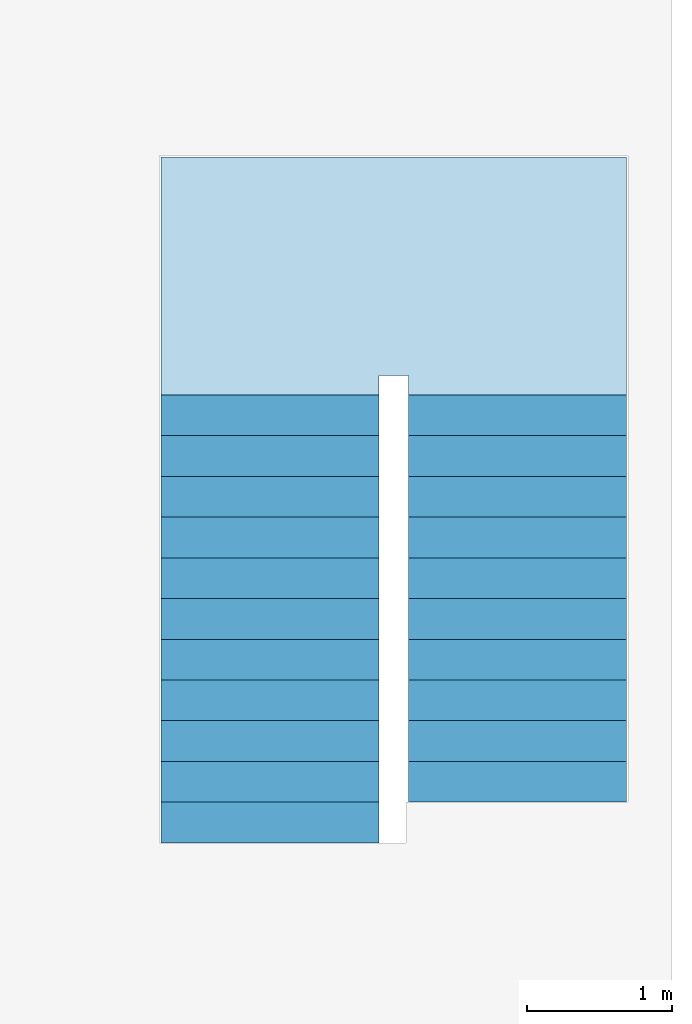
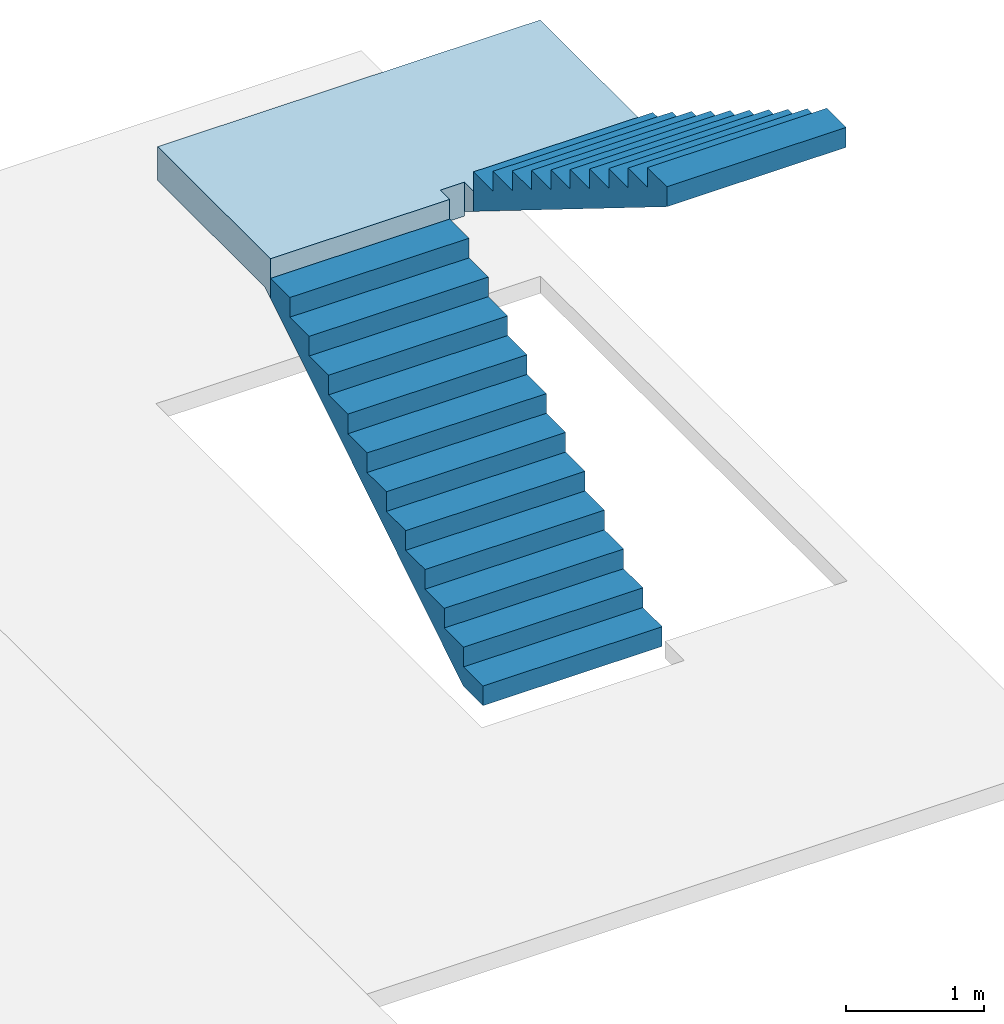
# One storey, part 2 of 2: 2 stair flights, 1 slab, 1 element without a shape of its own.
"""IFC2X3 building model written with IfcOpenShell, lengths in millimetres."""

from ifc_helpers import new_model, entity, si_unit, converted_unit, derived_unit, direction, frame, origin, place, context, subcontext, project, spatial, faceted_brep, material, element, aggregate, save


model = new_model("IFC2X3")

# Units and contexts
model_context = context("Model", 3, precision=0.01, world=origin(), true_north=direction((6.12303176911189e-17, 1.0)))
body_context = subcontext(model_context, "Body", "Model", "MODEL_VIEW")
ifc_project = project(units=[si_unit("LENGTHUNIT", "METRE", prefix="MILLI"), si_unit("AREAUNIT", "SQUARE_METRE"), si_unit("VOLUMEUNIT", "CUBIC_METRE"), converted_unit("PLANEANGLEUNIT", "DEGREE", entity("IfcRatioMeasure", 0.0174532925199433), si_unit("PLANEANGLEUNIT", "RADIAN"), dimensions=[0, 0, 0, 0, 0, 0, 0]), si_unit("MASSUNIT", "GRAM", prefix="KILO"), derived_unit("MASSDENSITYUNIT", [(si_unit("MASSUNIT", "GRAM", prefix="KILO"), 1), (si_unit("LENGTHUNIT", "METRE"), -3)]), si_unit("TIMEUNIT", "SECOND"), si_unit("FREQUENCYUNIT", "HERTZ"), si_unit("THERMODYNAMICTEMPERATUREUNIT", "DEGREE_CELSIUS"), derived_unit("THERMALTRANSMITTANCEUNIT", [(si_unit("MASSUNIT", "GRAM", prefix="KILO"), 1), (si_unit("THERMODYNAMICTEMPERATUREUNIT", "KELVIN"), -1), (si_unit("TIMEUNIT", "SECOND"), -3)]), derived_unit("VOLUMETRICFLOWRATEUNIT", [(si_unit("LENGTHUNIT", "METRE"), 3), (si_unit("TIMEUNIT", "SECOND"), -1)]), si_unit("ELECTRICCURRENTUNIT", "AMPERE"), si_unit("ELECTRICVOLTAGEUNIT", "VOLT"), si_unit("POWERUNIT", "WATT"), si_unit("FORCEUNIT", "NEWTON", prefix="KILO"), si_unit("ILLUMINANCEUNIT", "LUX"), si_unit("LUMINOUSFLUXUNIT", "LUMEN"), si_unit("LUMINOUSINTENSITYUNIT", "CANDELA"), derived_unit("USERDEFINED", [(si_unit("MASSUNIT", "GRAM", prefix="KILO"), -1), (si_unit("LENGTHUNIT", "METRE"), -2), (si_unit("TIMEUNIT", "SECOND"), 3), (si_unit("LUMINOUSFLUXUNIT", "LUMEN"), 1)]), derived_unit("LINEARVELOCITYUNIT", [(si_unit("LENGTHUNIT", "METRE"), 1), (si_unit("TIMEUNIT", "SECOND"), -1)]), si_unit("PRESSUREUNIT", "PASCAL"), derived_unit("USERDEFINED", [(si_unit("LENGTHUNIT", "METRE"), -2), (si_unit("MASSUNIT", "GRAM", prefix="KILO"), 1), (si_unit("TIMEUNIT", "SECOND"), -2)])], contexts=[model_context])

# Site, building, storey
site_placement = place(None, origin())
site = spatial("IfcSite", under=ifc_project, at=site_placement, CompositionType="ELEMENT")
building_placement = place(site_placement, origin())
building = spatial("IfcBuilding", under=site, at=building_placement, CompositionType="ELEMENT")
storey_placement = place(building_placement, frame((0.0, 0.0, 4000.0)))
storey = spatial("IfcBuildingStorey", under=building, at=storey_placement, Name="01 Level", CompositionType="ELEMENT", Elevation=4000.0)

# Stair, slab, stair flights
stair_placement = place(storey_placement, origin())
stair = element("IfcStair", 1, at=stair_placement, inside=storey, Name="Cast-In-Place Stair:Stair", ObjectType="Cast-In-Place Stair:Monolithic Stair", ShapeType="NOTDEFINED")
ifc_material = material(Name="Concrete, Cast In Situ")
slab_placement = place(stair_placement, frame((31263.4900708518, -68480.8241905963, 0.0)))
slab = element("IfcSlab", 2, at=slab_placement, material=ifc_material, Name="Cast-In-Place Stair:Stair:388632 Landing 1", ObjectType="Monolithic Landing:300mm Thickness", PredefinedType="LANDING", context=body_context, shape_type="Brep", body=[
    faceted_brep([(0.0, 0.0, 2086.95652173913), (1500.0, 0.0, 2086.95652173913), (1500.0, 81.2925429905189, 2086.95652173913), (1500.0, 135.0, 2086.95652173913), (1700.0, 135.0, 2086.95652173913), (1700.0, 0.0, 2086.95652173913), (3200.0, 0.0, 2086.95652173913), (3200.0, 198.707457009539, 2086.95652173913), (3200.0, 1635.0, 2086.95652173913), (0.0, 1635.0, 2086.95652173913), (0.0, 81.2925429905189, 2086.95652173913), (0.0, 0.0, 1913.04347826087), (0.0, 0.0, 1736.46425901212), (1500.0, 0.0, 1736.46425901212), (1500.0, 0.0, 1913.04347826087), (1500.0, 81.2925429905189, 1786.95652173913), (1500.0, 135.0, 1786.95652173913), (1700.0, 135.0, 1786.95652173913), (1700.0, 135.0, 1826.52637081337), (3200.0, 0.0, 1910.37730249039), (3200.0, 198.70745700953, 1786.95652173913), (3200.0, 1635.0, 1786.95652173913), (0.0, 1635.0, 1786.95652173913), (0.0, 81.2925429905189, 1786.95652173913), (1700.0, 198.70745700953, 1786.95652173913), (1700.0, 0.0, 1910.37730249039)], [[[0, 1, 2, 3, 4, 5, 6, 7, 8, 9, 10]], [[1, 0, 11, 12, 13, 14]], [[1, 14, 13, 15, 16, 3, 2]], [[4, 3, 16, 17, 18]], [[6, 19, 20, 21, 8, 7]], [[9, 8, 21, 22]], [[12, 11, 0, 10, 9, 22, 23]], [[24, 17, 16, 15, 23, 22, 21, 20]], [[17, 24, 18]], [[23, 15, 13, 12]], [[24, 20, 19, 25, 18]], [[5, 4, 18, 25]], [[6, 5, 25, 19]]]),
])
stair_flight_1_placement = place(stair_placement, frame((31263.4900708518, -71560.8241905963, 0.0)))
stair_flight_1 = element("IfcStairFlight", 3, at=stair_flight_1_placement, material=ifc_material, Name="Cast-In-Place Stair:Stair:388632 Run 1", ObjectType="Monolithic Run:150mm Depth", NumberOfRiser=12, NumberOfTreads=11, RiserHeight=0.57058085130663, TreadLength=0.918635170603675, context=body_context, shape_type="Brep", body=[
    faceted_brep([(0.0, 280.0, 173.913043478261), (0.0, 0.0, 173.913043478261), (1500.0, 0.0, 173.913043478261), (1500.0, 280.0, 173.913043478261), (0.0, 280.0, 0.0), (0.0, 0.0, 0.0), (1500.0, 0.0, 0.0), (1500.0, 280.0, 0.0), (0.0, 560.0, 347.826086956522), (0.0, 280.0, 347.826086956522), (1500.0, 280.0, 347.826086956522), (1500.0, 560.0, 347.826086956522), (0.0, 560.0, 171.246867707768), (0.0, 284.29254299049, 0.0), (1500.0, 284.29254299049, 0.0), (1500.0, 560.0, 171.246867707772), (0.0, 840.0, 521.739130434783), (0.0, 560.0, 521.739130434783), (1500.0, 560.0, 521.739130434783), (1500.0, 840.0, 521.739130434783), (0.0, 840.0, 345.159911186038), (1500.0, 840.0, 345.159911186036), (0.0, 1120.0, 695.652173913044), (0.0, 840.0, 695.652173913044), (1500.0, 840.0, 695.652173913044), (1500.0, 1120.0, 695.652173913044), (0.0, 1120.0, 519.07295466429), (1500.0, 1120.0, 519.072954664289), (0.0, 1400.0, 869.565217391304), (0.0, 1120.0, 869.565217391304), (1500.0, 1120.0, 869.565217391304), (1500.0, 1400.0, 869.565217391304), (0.0, 1400.0, 692.985998142542), (1500.0, 1400.0, 692.985998142554), (0.0, 1680.0, 1043.47826086956), (0.0, 1400.0, 1043.47826086956), (1500.0, 1400.0, 1043.47826086956), (1500.0, 1680.0, 1043.47826086956), (0.0, 1680.0, 866.899041620812), (1500.0, 1680.0, 866.899041620812), (0.0, 1960.0, 1217.39130434783), (0.0, 1680.0, 1217.39130434783), (1500.0, 1680.0, 1217.39130434783), (1500.0, 1960.0, 1217.39130434783), (0.0, 1960.0, 1040.81208509906), (1500.0, 1960.0, 1040.81208509907), (0.0, 2240.0, 1391.30434782609), (0.0, 1960.0, 1391.30434782609), (1500.0, 1960.0, 1391.30434782609), (1500.0, 2240.0, 1391.30434782609), (0.0, 2240.0, 1214.72512857734), (1500.0, 2240.0, 1214.72512857734), (0.0, 2520.0, 1565.21739130435), (0.0, 2240.0, 1565.21739130435), (1500.0, 2240.0, 1565.21739130435), (1500.0, 2520.0, 1565.21739130435), (0.0, 2520.0, 1388.63817205559), (1500.0, 2520.0, 1388.63817205559), (0.0, 2800.0, 1739.13043478261), (0.0, 2520.0, 1739.13043478261), (1500.0, 2520.0, 1739.13043478261), (1500.0, 2800.0, 1739.13043478261), (0.0, 2800.0, 1562.55121553385), (1500.0, 2800.0, 1562.55121553386), (0.0, 3080.0, 1913.04347826087), (0.0, 2800.0, 1913.04347826087), (1500.0, 2800.0, 1913.04347826087), (1500.0, 3080.0, 1913.04347826087), (0.0, 3080.0, 1736.46425901212), (1500.0, 3080.0, 1736.46425901212)], [[[0, 1, 2, 3]], [[1, 0, 4, 5]], [[2, 1, 5, 6]], [[3, 2, 6, 7]], [[8, 9, 10, 11]], [[4, 0, 9, 8, 12, 13]], [[0, 3, 10, 9]], [[3, 7, 14, 15, 11, 10]], [[16, 17, 18, 19]], [[17, 16, 20, 12, 8]], [[8, 11, 18, 17]], [[19, 18, 11, 15, 21]], [[22, 23, 24, 25]], [[23, 22, 26, 20, 16]], [[16, 19, 24, 23]], [[25, 24, 19, 21, 27]], [[28, 29, 30, 31]], [[29, 28, 32, 26, 22]], [[22, 25, 30, 29]], [[31, 30, 25, 27, 33]], [[34, 35, 36, 37]], [[35, 34, 38, 32, 28]], [[28, 31, 36, 35]], [[37, 36, 31, 33, 39]], [[40, 41, 42, 43]], [[41, 40, 44, 38, 34]], [[34, 37, 42, 41]], [[43, 42, 37, 39, 45]], [[46, 47, 48, 49]], [[47, 46, 50, 44, 40]], [[40, 43, 48, 47]], [[49, 48, 43, 45, 51]], [[52, 53, 54, 55]], [[53, 52, 56, 50, 46]], [[46, 49, 54, 53]], [[55, 54, 49, 51, 57]], [[58, 59, 60, 61]], [[59, 58, 62, 56, 52]], [[52, 55, 60, 59]], [[61, 60, 55, 57, 63]], [[64, 65, 66, 67]], [[65, 64, 68, 62, 58]], [[58, 61, 66, 65]], [[67, 66, 61, 63, 69]], [[64, 67, 69, 68]], [[5, 4, 13, 14, 7, 6]], [[14, 13, 12, 20, 26, 32, 38, 44, 50, 56, 62, 68, 69, 63, 57, 51, 45, 39, 33, 27, 21, 15]]]),
])
stair_flight_2_placement = place(stair_placement, frame((32963.4900708518, -71280.8241905964, 0.0)))
stair_flight_2 = element("IfcStairFlight", 4, at=stair_flight_2_placement, material=ifc_material, Name="Cast-In-Place Stair:Stair:388632 Run 2", ObjectType="Monolithic Run:150mm Depth", NumberOfRiser=11, NumberOfTreads=10, RiserHeight=0.57058085130663, TreadLength=0.918635170603675, context=body_context, shape_type="Brep", body=[
    faceted_brep([(1500.0, 2520.0, 2260.86956521739), (1500.0, 2800.0, 2260.86956521739), (0.0, 2800.0, 2260.86956521739), (0.0, 2520.0, 2260.86956521739), (1500.0, 2520.0, 2084.29034596864), (1500.0, 2800.0, 1910.37730249038), (1500.0, 2800.0, 2086.95652173913), (0.0, 2800.0, 1910.37730249038), (0.0, 2800.0, 2086.95652173913), (0.0, 2520.0, 2084.29034596864), (1500.0, 2240.0, 2434.78260869565), (1500.0, 2520.0, 2434.78260869565), (0.0, 2520.0, 2434.78260869565), (0.0, 2240.0, 2434.78260869565), (1500.0, 2240.0, 2258.20338944691), (0.0, 2240.0, 2258.2033894469), (1500.0, 1960.0, 2608.69565217391), (1500.0, 2240.0, 2608.69565217391), (0.0, 2240.0, 2608.69565217391), (0.0, 1960.0, 2608.69565217391), (1500.0, 1960.0, 2432.11643292516), (0.0, 1960.0, 2432.11643292516), (1500.0, 1680.0, 2782.60869565217), (1500.0, 1960.0, 2782.60869565217), (0.0, 1960.0, 2782.60869565217), (0.0, 1680.0, 2782.60869565217), (1500.0, 1680.0, 2606.02947640343), (0.0, 1680.0, 2606.02947640342), (1500.0, 1400.0, 2956.52173913043), (1500.0, 1680.0, 2956.52173913043), (0.0, 1680.0, 2956.52173913043), (0.0, 1400.0, 2956.52173913043), (1500.0, 1400.0, 2779.94251988169), (0.0, 1400.0, 2779.94251988169), (1500.0, 1120.0, 3130.4347826087), (1500.0, 1400.0, 3130.4347826087), (0.0, 1400.0, 3130.4347826087), (0.0, 1120.0, 3130.4347826087), (1500.0, 1120.0, 2953.85556335994), (0.0, 1120.0, 2953.85556335994), (1500.0, 840.0, 3304.34782608696), (1500.0, 1120.0, 3304.34782608696), (0.0, 1120.0, 3304.34782608696), (0.0, 840.0, 3304.34782608696), (1500.0, 840.0, 3127.7686068382), (0.0, 840.0, 3127.7686068382), (1500.0, 560.0, 3478.26086956522), (1500.0, 840.0, 3478.26086956522), (0.0, 840.0, 3478.26086956522), (0.0, 560.0, 3478.26086956522), (1500.0, 560.0, 3301.68165031647), (0.0, 560.0, 3301.68165031646), (1500.0, 280.0, 3652.17391304348), (1500.0, 560.0, 3652.17391304348), (0.0, 560.0, 3652.17391304348), (0.0, 280.0, 3652.17391304348), (1500.0, 280.0, 3475.59469379473), (0.0, 280.0, 3475.59469379472), (1500.0, 0.0, 3826.08695652174), (1500.0, 280.0, 3826.08695652174), (0.0, 280.0, 3826.08695652174), (0.0, 0.0, 3826.08695652174), (1500.0, 0.0, 3649.50773727299), (0.0, 0.0, 3649.50773727299)], [[[0, 1, 2, 3]], [[1, 0, 4, 5, 6]], [[2, 1, 6, 5, 7, 8]], [[3, 2, 8, 7, 9]], [[10, 11, 12, 13]], [[11, 10, 14, 4, 0]], [[12, 11, 0, 3]], [[13, 12, 3, 9, 15]], [[16, 17, 18, 19]], [[17, 16, 20, 14, 10]], [[18, 17, 10, 13]], [[19, 18, 13, 15, 21]], [[22, 23, 24, 25]], [[23, 22, 26, 20, 16]], [[24, 23, 16, 19]], [[25, 24, 19, 21, 27]], [[28, 29, 30, 31]], [[29, 28, 32, 26, 22]], [[30, 29, 22, 25]], [[31, 30, 25, 27, 33]], [[34, 35, 36, 37]], [[35, 34, 38, 32, 28]], [[36, 35, 28, 31]], [[37, 36, 31, 33, 39]], [[40, 41, 42, 43]], [[41, 40, 44, 38, 34]], [[42, 41, 34, 37]], [[43, 42, 37, 39, 45]], [[46, 47, 48, 49]], [[47, 46, 50, 44, 40]], [[48, 47, 40, 43]], [[49, 48, 43, 45, 51]], [[52, 53, 54, 55]], [[53, 52, 56, 50, 46]], [[54, 53, 46, 49]], [[55, 54, 49, 51, 57]], [[58, 59, 60, 61]], [[59, 58, 62, 56, 52]], [[60, 59, 52, 55]], [[61, 60, 55, 57, 63]], [[58, 61, 63, 62]], [[5, 4, 14, 20, 26, 32, 38, 44, 50, 56, 62, 63, 57, 51, 45, 39, 33, 27, 21, 15, 9, 7]]]),
])
aggregate(stair, [stair_flight_1, stair_flight_2, slab])

save(model, "model.ifc")
